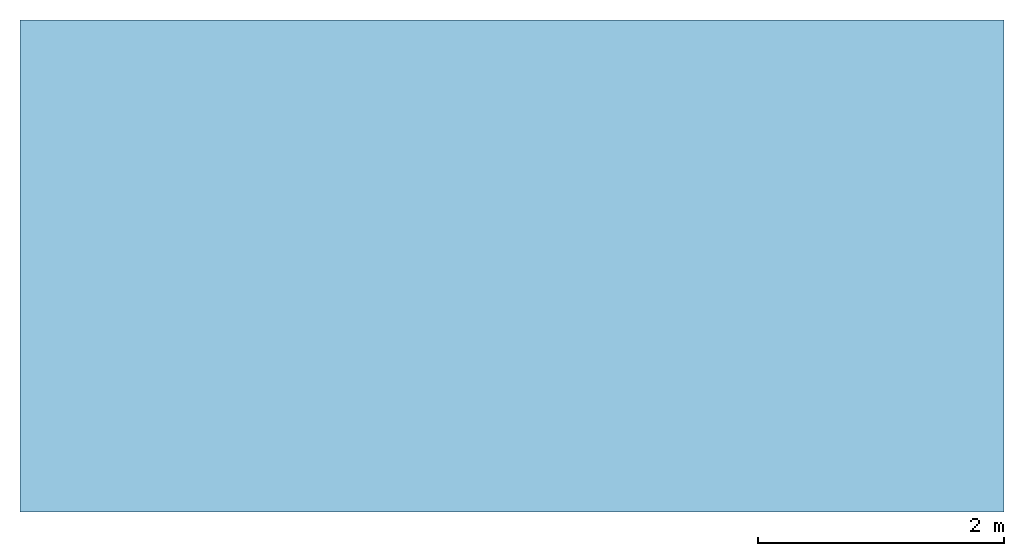
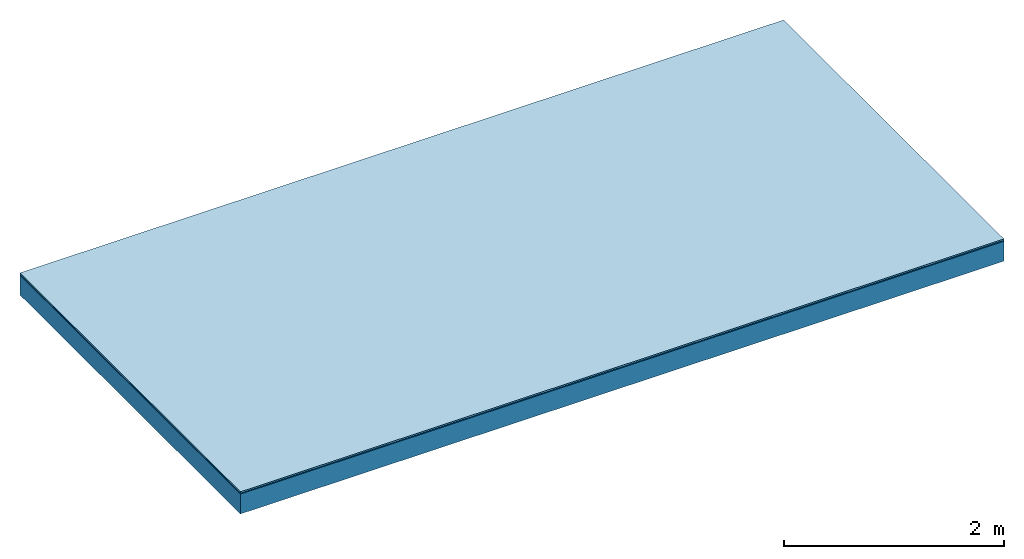
# One storey: 3 plates, 1 member, 1 element without a shape of its own.
"""IFC4 building model written with IfcOpenShell, lengths in metres."""

from ifc_helpers import new_model, si_unit, derived_unit, direction, frame, frame_2d, origin, origin_with_axes, place, context, project, spatial, rectangle, extrude, material, layer, layer_set, type_object, element, aggregate, save


model = new_model("IFC4")

# Units and contexts
plan_context = context("Plan", 3, precision=1e-05, world=origin(), true_north=direction((0.0, 1.0)))
model_context = context("Model", 3, precision=1e-05, world=origin(), true_north=direction((0.0, 1.0)))
ifc_project = project(units=[si_unit("LENGTHUNIT", "METRE"), derived_unit("SOUNDPRESSUREUNIT", [(si_unit("PRESSUREUNIT", "PASCAL", prefix="MICRO"), 0)]), si_unit("ENERGYUNIT", "JOULE", prefix="MEGA"), si_unit("MASSUNIT", "GRAM", prefix="KILO"), derived_unit("THERMALTRANSMITTANCEUNIT", [(si_unit("POWERUNIT", "WATT"), 1), (si_unit("AREAUNIT", "SQUARE_METRE"), -1), (si_unit("THERMODYNAMICTEMPERATUREUNIT", "KELVIN"), -1)]), derived_unit("AREADENSITYUNIT", [(si_unit("MASSUNIT", "GRAM", prefix="KILO"), 1), (si_unit("AREAUNIT", "SQUARE_METRE"), -1)]), derived_unit("USERDEFINED", [(si_unit("ENERGYUNIT", "JOULE", prefix="MEGA"), 1), (si_unit("AREAUNIT", "SQUARE_METRE"), -1)])], contexts=[plan_context, model_context])

# Site, building, storey
site = spatial("IfcSite", under=ifc_project)
building_placement = place(None, origin())
building = spatial("IfcBuilding", under=site, at=building_placement)
storey_placement = place(building_placement, origin())
storey = spatial("IfcBuildingStorey", under=building, at=storey_placement)

# Slab, member, plates
ifc_material_1 = material(Category="11.013")
ifc_layer_1 = layer(ifc_material_1, 0.015, Name="Flooring")
ifc_material_2 = material(Name="Wood fiber generic product", Category="10.009")
ifc_layer_2 = layer(ifc_material_2, 0.01, Name="Impact sound insulation")
ifc_material_3 = material(Name="protection", Category="09.007")
ifc_layer_3 = layer(ifc_material_3, 0.0005, Name="Sub-floor")
ifc_material_4 = material(Name="no composite action")
ifc_layer_4 = layer(ifc_material_4, 0.0, Name="Bond")
ifc_layer_5 = layer(None, 0.22, Name="Supporting structure")
ifc_layer_set = layer_set([ifc_layer_1, ifc_layer_2, ifc_layer_3, ifc_layer_4, ifc_layer_5])
slab_type = type_object("IfcSlabType", Name="A2011", PredefinedType="NOTDEFINED", material=ifc_layer_set)
slab_placement = place(None, frame((0.0, 0.0, 0.0), z_axis=(0.0, 0.0, -1.0), x_axis=(1.0, 0.0, 0.0)))
slab = element("IfcSlab", 1, at=slab_placement, inside=storey, type_object=slab_type, material=ifc_layer_set, Name="Slab #1")
ifc_material_5 = material(Name="Solid timber panel")
member_placement = place(slab_placement, origin())
member = element("IfcMember", 2, at=member_placement, material=ifc_material_5, Name="Supporting structure", context=plan_context, shape_type="SweptSolid", body=[
    extrude(rectangle(XDim=1.0, YDim=0.22, at=frame_2d((0.5, 0.11), x_axis=(1.0, 0.0))), frame((0.0, 4.0, 0.0255), z_axis=(0.0, -1.0, 0.0), x_axis=(1.0, 0.0, 0.0)), (0.0, 0.0, 1.0), 4.0),
    extrude(rectangle(XDim=1.0, YDim=0.22, at=frame_2d((0.5, 0.11), x_axis=(1.0, 0.0))), frame((1.0, 4.0, 0.0255), z_axis=(0.0, -1.0, 0.0), x_axis=(1.0, 0.0, 0.0)), (0.0, 0.0, 1.0), 4.0),
    extrude(rectangle(XDim=1.0, YDim=0.22, at=frame_2d((0.5, 0.11), x_axis=(1.0, 0.0))), frame((2.0, 4.0, 0.0255), z_axis=(0.0, -1.0, 0.0), x_axis=(1.0, 0.0, 0.0)), (0.0, 0.0, 1.0), 4.0),
    extrude(rectangle(XDim=1.0, YDim=0.22, at=frame_2d((0.5, 0.11), x_axis=(1.0, 0.0))), frame((3.0, 4.0, 0.0255), z_axis=(0.0, -1.0, 0.0), x_axis=(1.0, 0.0, 0.0)), (0.0, 0.0, 1.0), 4.0),
    extrude(rectangle(XDim=1.0, YDim=0.22, at=frame_2d((0.5, 0.11), x_axis=(1.0, 0.0))), frame((4.0, 4.0, 0.0255), z_axis=(0.0, -1.0, 0.0), x_axis=(1.0, 0.0, 0.0)), (0.0, 0.0, 1.0), 4.0),
    extrude(rectangle(XDim=1.0, YDim=0.22, at=frame_2d((0.5, 0.11), x_axis=(1.0, 0.0))), frame((5.0, 4.0, 0.0255), z_axis=(0.0, -1.0, 0.0), x_axis=(1.0, 0.0, 0.0)), (0.0, 0.0, 1.0), 4.0),
    extrude(rectangle(XDim=1.0, YDim=0.22, at=frame_2d((0.5, 0.11), x_axis=(1.0, 0.0))), frame((6.0, 4.0, 0.0255), z_axis=(0.0, -1.0, 0.0), x_axis=(1.0, 0.0, 0.0)), (0.0, 0.0, 1.0), 4.0),
    extrude(rectangle(XDim=1.0, YDim=0.22, at=frame_2d((0.5, 0.11), x_axis=(1.0, 0.0))), frame((7.0, 4.0, 0.0255), z_axis=(0.0, -1.0, 0.0), x_axis=(1.0, 0.0, 0.0)), (0.0, 0.0, 1.0), 4.0),
])
plate_1_placement = place(slab_placement, origin())
plate_1 = element("IfcPlate", 3, at=plate_1_placement, material=ifc_material_1, Name="Flooring", context=plan_context, shape_type="SweptSolid", body=[
    extrude(rectangle(XDim=8.0, YDim=4.0, at=frame_2d((4.0, 2.0), x_axis=(1.0, 0.0))), origin_with_axes(), (0.0, 0.0, 1.0), 0.015),
])
plate_2_placement = place(slab_placement, origin())
plate_2 = element("IfcPlate", 4, at=plate_2_placement, material=ifc_material_2, Name="Impact sound insulation", context=plan_context, shape_type="SweptSolid", body=[
    extrude(rectangle(XDim=8.0, YDim=4.0, at=frame_2d((4.0, 2.0), x_axis=(1.0, 0.0))), frame((0.0, 0.0, 0.015), z_axis=(0.0, 0.0, 1.0), x_axis=(1.0, 0.0, 0.0)), (0.0, 0.0, 1.0), 0.01),
])
plate_3_placement = place(slab_placement, origin())
plate_3 = element("IfcPlate", 5, at=plate_3_placement, material=ifc_material_3, Name="Sub-floor", context=plan_context, shape_type="SweptSolid", body=[
    extrude(rectangle(XDim=8.0, YDim=4.0, at=frame_2d((4.0, 2.0), x_axis=(1.0, 0.0))), frame((0.0, 0.0, 0.025), z_axis=(0.0, 0.0, 1.0), x_axis=(1.0, 0.0, 0.0)), (0.0, 0.0, 1.0), 0.0005),
])
aggregate(slab, [plate_1, plate_2, plate_3, member])

save(model, "model.ifc")
